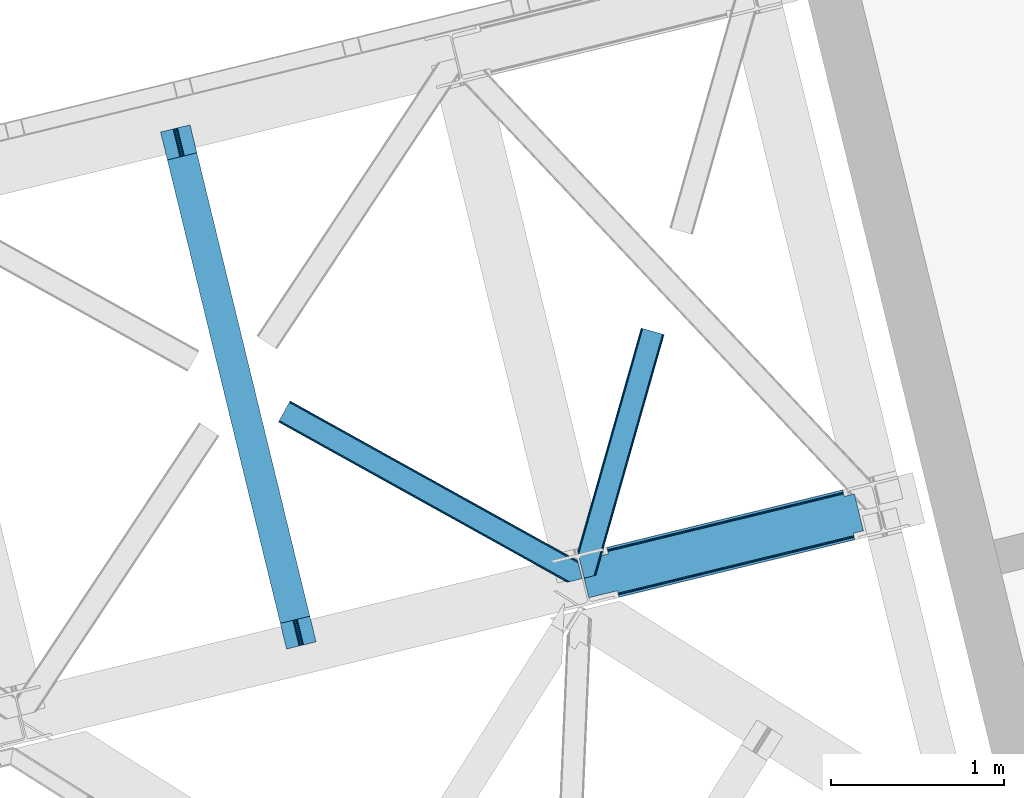
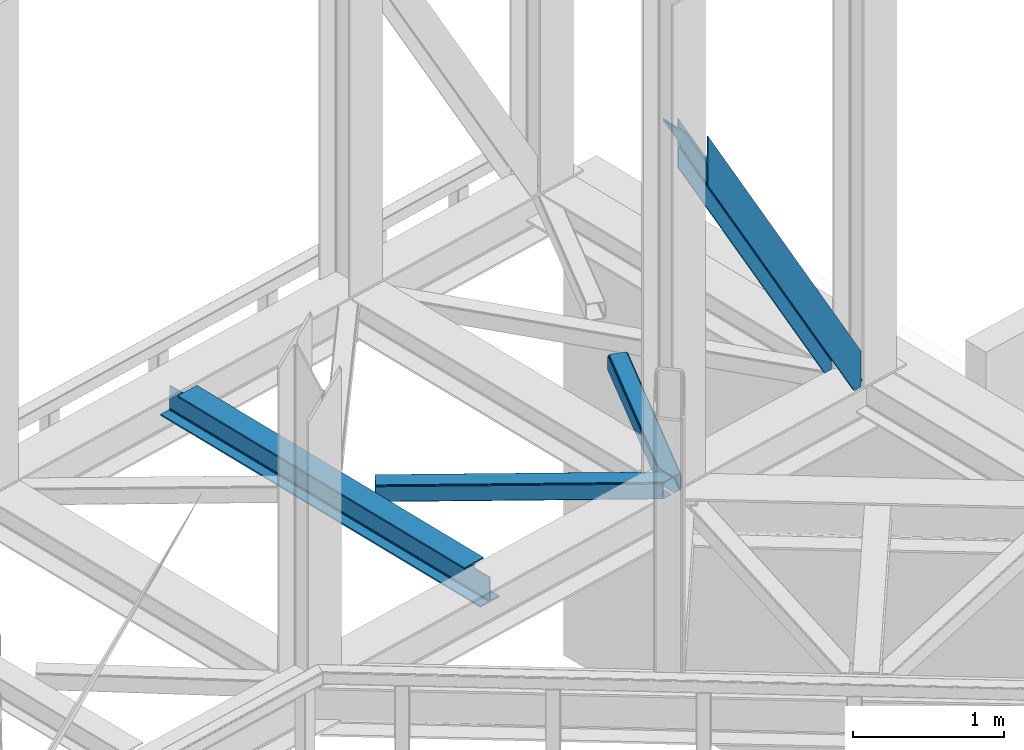
# One storey, part 82 of 93: 3 members, 1 beam.
"""IFC4 building model written with IfcOpenShell, lengths in millimetres."""

from ifc_helpers import new_model, entity, si_unit, converted_unit, derived_unit, direction, frame, origin, place, context, subcontext, project, spatial, triangles, polygons, material, type_object, element, save


model = new_model("IFC4")

# Units and contexts
model_context = context("Model", 3, precision=0.01, world=origin(), true_north=direction((6.12303176911189e-17, 1.0)))
plan_context = context("Plan", 3, precision=0.01, world=origin(), true_north=direction((6.12303176911189e-17, 1.0)))
body_context = subcontext(model_context, "Body", "Model", "MODEL_VIEW")
ifc_project = project(units=[si_unit("LENGTHUNIT", "METRE", prefix="MILLI"), si_unit("AREAUNIT", "SQUARE_METRE"), si_unit("VOLUMEUNIT", "CUBIC_METRE"), converted_unit("PLANEANGLEUNIT", "DEGREE", entity("IfcRatioMeasure", 0.0174532925199433), si_unit("PLANEANGLEUNIT", "RADIAN"), dimensions=[0, 0, 0, 0, 0, 0, 0]), si_unit("MASSUNIT", "GRAM", prefix="KILO"), derived_unit("MASSDENSITYUNIT", [(si_unit("MASSUNIT", "GRAM", prefix="KILO"), 1), (si_unit("LENGTHUNIT", "METRE"), -3)]), derived_unit("MOMENTOFINERTIAUNIT", [(si_unit("LENGTHUNIT", "METRE"), 4)]), si_unit("TIMEUNIT", "SECOND"), si_unit("FREQUENCYUNIT", "HERTZ"), si_unit("THERMODYNAMICTEMPERATUREUNIT", "DEGREE_CELSIUS"), derived_unit("THERMALTRANSMITTANCEUNIT", [(si_unit("MASSUNIT", "GRAM", prefix="KILO"), 1), (si_unit("THERMODYNAMICTEMPERATUREUNIT", "KELVIN"), -1), (si_unit("TIMEUNIT", "SECOND"), -3)]), derived_unit("VOLUMETRICFLOWRATEUNIT", [(si_unit("LENGTHUNIT", "METRE"), 3), (si_unit("TIMEUNIT", "SECOND"), -1)]), derived_unit("MASSFLOWRATEUNIT", [(si_unit("MASSUNIT", "GRAM", prefix="KILO"), 1), (si_unit("TIMEUNIT", "SECOND"), -1)]), derived_unit("ROTATIONALFREQUENCYUNIT", [(si_unit("TIMEUNIT", "SECOND"), -1)]), si_unit("ELECTRICCURRENTUNIT", "AMPERE"), si_unit("ELECTRICVOLTAGEUNIT", "VOLT"), si_unit("POWERUNIT", "WATT"), si_unit("FORCEUNIT", "NEWTON", prefix="KILO"), si_unit("ILLUMINANCEUNIT", "LUX"), si_unit("LUMINOUSFLUXUNIT", "LUMEN"), si_unit("LUMINOUSINTENSITYUNIT", "CANDELA"), derived_unit("USERDEFINED", [(si_unit("MASSUNIT", "GRAM", prefix="KILO"), -1), (si_unit("LENGTHUNIT", "METRE"), -2), (si_unit("TIMEUNIT", "SECOND"), 3), (si_unit("LUMINOUSFLUXUNIT", "LUMEN"), 1)]), derived_unit("LINEARVELOCITYUNIT", [(si_unit("LENGTHUNIT", "METRE"), 1), (si_unit("TIMEUNIT", "SECOND"), -1)]), si_unit("PRESSUREUNIT", "PASCAL"), derived_unit("USERDEFINED", [(si_unit("LENGTHUNIT", "METRE"), -2), (si_unit("MASSUNIT", "GRAM", prefix="KILO"), 1), (si_unit("TIMEUNIT", "SECOND"), -2)]), derived_unit("LINEARFORCEUNIT", [(si_unit("MASSUNIT", "GRAM", prefix="KILO"), 1), (si_unit("LENGTHUNIT", "METRE"), 1), (si_unit("TIMEUNIT", "SECOND"), -2), (si_unit("LENGTHUNIT", "METRE"), -1)]), derived_unit("PLANARFORCEUNIT", [(si_unit("MASSUNIT", "GRAM", prefix="KILO"), 1), (si_unit("LENGTHUNIT", "METRE"), 1), (si_unit("TIMEUNIT", "SECOND"), -2), (si_unit("LENGTHUNIT", "METRE"), -2)])], contexts=[model_context, plan_context])

# Site, building, storey
site_placement = place(None, origin())
site = spatial("IfcSite", under=ifc_project, at=site_placement, CompositionType="ELEMENT")
building_placement = place(site_placement, origin())
building = spatial("IfcBuilding", under=site, at=building_placement, CompositionType="ELEMENT")
storey_placement = place(building_placement, frame((0.0, 0.0, 15900.0)))
storey = spatial("IfcBuildingStorey", under=building, at=storey_placement, CompositionType="ELEMENT", Elevation=15900.0)

# Beam
ifc_material = material(Name="Metal painted (White)")
beam_type = type_object("IfcBeamType", PredefinedType="BEAM")
beam_placement = place(storey_placement, frame((-4605.04883182571, 16672.3998394373, 3441.0)))
element("IfcBeam", 1, at=beam_placement, inside=storey, type_object=beam_type, material=ifc_material, ObjectType="Steel Beam", PredefinedType="BEAM", context=body_context, shape_type="Tessellation", body=[
    polygons([(896.722476515621, 41.4445662733103, 11.000000000004), (896.72247651562, 41.4445662733103, 2.16573425859679e-12), (170.02161017477, 3022.65205668042, 2.16573425859679e-12), (170.02161017477, 3022.65205668042, 11.000000000004), (830.656936562001, 25.3403919499699, 11.000000000004), (103.95607022115, 3006.54788235708, 11.000000000004), (824.708186540703, 23.8903211957417, 12.2179274798217), (98.007320199853, 3005.09781160286, 12.2179274798217), (819.665079784591, 22.6610105689216, 15.6862915010257), (92.9642134437405, 3003.86850097604, 15.6862915010257), (816.295383581418, 21.839611468714, 20.8770650821657), (89.5945172405684, 3003.04710187583, 20.8770650821657), (815.112103631724, 21.5511744621227, 27.0000000000047), (88.4112372908739, 3002.75866486924, 27.0000000000047), (81.6103728838909, 3001.1008822183, 27.0000000000047), (81.6103728838915, 3001.10088221831, 203.000000000006), (88.4112372908706, 3002.75866486924, 203.000000000006), (5.41433564649196e-13, 2981.20749040711, 2.16573425859679e-12), (2.16573425859679e-12, 2981.20749040711, 10.9999999999997), (66.0655399536302, 2997.31166473046, 11.000000000004), (72.0142899749205, 2998.76173548468, 12.2179274798195), (77.0573967310308, 2999.99104611151, 15.6862915010192), (80.427092934211, 3000.81244521171, 20.8770650821657), (815.112103631721, 21.5511744621206, 203.000000000006), (808.311239224742, 19.8933918111897, 203.000000000006), (808.311239224741, 19.8933918111897, 27.0000000000047), (807.127959275061, 19.6049548046028, 20.8770650821657), (803.75826307188, 18.7835557043952, 15.6862915010192), (798.71515631577, 17.5542450775707, 12.2179274798195), (792.76640629448, 16.104174323349, 11.000000000004), (726.700866340852, 2.16573425859679e-12, 10.9999999999997), (726.700866340851, 2.16573425859679e-12, 2.16573425859679e-12), (779.142354126241, 169.113117828151, 203.069793472056), (127.487542634277, 2842.45257527589, 203.000000000006), (127.710423423425, 2841.53823284147, 203.617301946336), (127.723337667946, 2841.48525286857, 217.000003693143), (778.997150924595, 169.708652488344, 217.000003676718), (778.998021532492, 169.705081047464, 204.00000679514), (772.432053048639, 167.083518913905, 203.006342977999), (772.209205347559, 167.99787105405, 203.617301946336), (772.196291103036, 168.050851026943, 217.000003693143), (120.922477846387, 2839.82745140717, 217.000003676718), (120.921607238492, 2839.83102284805, 204.00000679514), (120.77730764944, 2840.42299574862, 203.076120467494), (120.686678227296, 2840.79479262496, 203.000000000006), (780.180635648643, 169.996249461788, 223.122939328039), (783.549632057316, 170.820519285667, 228.313710402595), (788.592267461342, 172.051763510973, 231.782072735464), (794.540846332051, 173.502536365655, 232.999999602236), (860.606297197569, 189.607076149589, 232.999999283132), (860.604823861134, 189.613120126462, 243.999994005812), (690.583442957211, 148.167613329572, 243.999994827032), (690.58491629365, 148.161569352698, 233.000000104353), (756.650367159178, 164.266109136635, 232.999999785253), (762.599272287504, 165.715543604856, 231.782072861016), (767.642836794641, 166.94297642799, 228.313710479427), (771.01322370438, 167.761542085424, 223.12293937232), (119.738993122354, 2839.53985443373, 223.122939328039), (116.369996713678, 2838.71558460985, 228.313710402595), (111.327361309646, 2837.48434038454, 231.782072735464), (105.378782438949, 2836.03356752986, 232.999999602236), (39.3133315734155, 2819.92902774593, 232.999999283128), (39.3148049098525, 2819.92298376905, 243.999994005812), (209.336185813776, 2861.36849056595, 243.999994827032), (209.334712477334, 2861.37453454282, 233.000000104357), (143.269261611822, 2845.26999475889, 232.999999785253), (137.320356483485, 2843.82056029066, 231.782072861012), (132.276791976353, 2842.59312746752, 228.313710479427), (128.906405066617, 2841.77456181009, 223.12293937232)], [[[1, 2, 3, 4]], [[5, 1, 4, 6]], [[7, 5, 6, 8]], [[9, 7, 8, 10]], [[11, 9, 10, 12]], [[13, 11, 12, 14]], [[15, 16, 17, 14, 12, 10, 8, 6, 4, 3, 18, 19, 20, 21, 22, 23]], [[13, 24, 25, 26, 27, 28, 29, 30, 31, 32, 2, 1, 5, 7, 9, 11]], [[2, 32, 18, 3]], [[32, 31, 19, 18]], [[31, 30, 20, 19]], [[27, 26, 15, 23]], [[28, 27, 23, 22]], [[29, 28, 22, 21]], [[30, 29, 21, 20]], [[33, 24, 13, 14, 17, 34, 35, 36, 37, 38]], [[25, 39, 40, 41, 42, 43, 44, 16, 15, 26]], [[39, 25, 24, 33]], [[45, 34, 17, 16]], [[41, 40, 38, 37, 46, 47, 48, 49, 50, 51, 52, 53, 54, 55, 56, 57]], [[42, 58, 59, 60, 61, 62, 63, 64, 65, 66, 67, 68, 69, 36, 35, 43]], [[46, 37, 36, 69]], [[47, 46, 69, 68]], [[48, 47, 68, 67]], [[49, 48, 67, 66]], [[50, 49, 66, 65]], [[51, 50, 65, 64]], [[52, 51, 64, 63]], [[53, 52, 63, 62]], [[54, 53, 62, 61]], [[55, 54, 61, 60]], [[56, 55, 60, 59]], [[57, 56, 59, 58]], [[41, 57, 58, 42]]], closed=False),
])

# Members
member_type_1 = type_object("IfcMemberType", PredefinedType="BRACE")
member_1_placement = place(storey_placement, frame((-2187.21835717022, 16968.3557591436, 3695.0)))
element("IfcMember", 2, at=member_1_placement, inside=storey, type_object=member_type_1, ObjectType="Steel Vertical Brace", PredefinedType="BRACE", context=body_context, shape_type="Tessellation", body=[
    polygons([(1523.65378747275, 333.032085942706, 0.0), (1582.15074591361, 347.2913384483, 0.0), (1585.22948512248, 334.661161692462, 0.0), (1526.73252668162, 320.401909186869, 0.0), (225.056603724429, 3.10463150599028, 2308.00987734577), (221.977864515554, 15.734808261831, 2308.00987734577), (221.977864515553, 15.734808261831, 2462.87833808595), (1582.1507459136, 347.291338448298, 51.1471308030944), (225.056603724427, 3.10463150599028, 2706.38533905685), (1585.22948512248, 334.661161692462, 294.654131773986), (217.71499484172, 33.2227453083746, 2515.66308676267), (216.294038283785, 39.0520576572275, 2515.66308676267), (216.294038283786, 39.0520576572275, 2498.73212963995), (217.714994841717, 33.2227453083768, 2498.73212963995), (219.34632444024, 26.5304015344206, 2496.00292226562), (220.72929889541, 20.8569064337962, 2488.23079722503), (221.653372883133, 17.065998205232, 2476.59899010114), (221.977864515552, 15.734808261831, 2706.38533905685), (221.977864515552, 15.734808261831, 2551.51687831667), (221.653372883138, 17.0659982052385, 2537.79622630148), (220.729298895404, 20.856906433807, 2526.16441917759), (219.346324440226, 26.5304015344141, 2518.39229413699), (1576.46691968183, 370.608587843693, 87.0009223570892), (1576.46691968183, 370.608587843693, 103.931879479809), (1577.88787623976, 364.779275494842, 103.9318794798), (1579.51920583827, 358.086931720883, 106.661086854137), (1580.90218029345, 352.413436620276, 114.433211894731), (1581.82625428118, 348.622528391703, 126.065019018618), (1582.15074591359, 347.291338448298, 139.785671033808), (1582.15074591359, 347.291338448298, 294.654131773986), (1581.82625428118, 348.622528391697, 64.8677828182753), (1580.90218029345, 352.413436620263, 76.4995899421711), (1579.51920583828, 358.086931720888, 84.2717149827655), (1577.88787623976, 364.779275494846, 87.0009223570848), (163.955471732923, 253.765062506492, 2498.73212963995), (162.534515174981, 259.594374855341, 2498.73212963995), (1522.70739657303, 591.15090504181, 87.0009223570935), (1524.12835313097, 585.321592692961, 87.0009223570935), (1524.73254220655, 584.95422971039, 86.1395897830593), (1525.33673128212, 584.586866727814, 85.2782572090295), (1573.43212950823, 596.310628884719, 0.0), (1625.29704387311, 383.540728151737, 0.0), (1577.201645647, 371.81696599483, 85.2782572090295), (1576.83428266443, 371.212776919264, 86.1395897830593), (215.689849208223, 39.4194206398013, 2499.59346221398), (215.085660132657, 39.7867836223773, 2500.45479478801), (51.8649143648901, 2.16573425859679e-12, 2789.86253966195), (6.76791955811495e-12, 212.769900732984, 2789.86253966195), (163.220745767773, 252.556684355359, 2500.45479478801), (163.588108750349, 253.160873430927, 2499.59346221398), (163.220745767771, 252.556684355359, 2517.38575191073), (5.41433564649196e-13, 212.769900732984, 2806.79349678468), (51.8649143648844, 0.0, 2806.79349678468), (215.085660132655, 39.7867836223773, 2517.38575191073), (215.68984920822, 39.4194206398013, 2516.5244193367), (1576.83428266442, 371.212776919264, 103.070546905779), (1577.201645647, 371.81696599483, 102.209214331749), (1634.84579817246, 385.868338036035, 0.0), (1582.98088380758, 598.638238769017, 0.0), (1525.33673128211, 584.586866727814, 102.209214331749), (1524.73254220655, 584.954229710388, 103.070546905779), (1524.12835313097, 585.321592692961, 103.931879479813), (1522.70739657303, 591.15090504181, 103.931879479809), (162.534515174979, 259.594374855341, 2515.66308676267), (163.955471732921, 253.765062506492, 2515.66308676267), (163.588108750346, 253.160873430927, 2516.5244193367), (160.903185576473, 266.286718629297, 2518.39229413699), (159.520211121304, 271.960213729915, 2526.16441917758), (158.596137133563, 275.751121958494, 2537.79622630147), (158.271645501151, 277.082311901891, 2551.51687831666), (158.271645501151, 277.082311901886, 2706.38533905685), (155.192906292277, 289.712488657727, 2706.38533905685), (155.192906292278, 289.712488657727, 2308.00987734577), (158.271645501152, 277.082311901886, 2308.00987734577), (158.271645501151, 277.082311901886, 2462.87833808595), (158.596137133566, 275.75112195849, 2476.59899010114), (159.520211121302, 271.960213729923, 2488.23079722503), (160.903185576474, 266.286718629303, 2496.00292226561), (1521.07606697452, 597.843248815768, 84.2717149827568), (1519.69309251934, 603.516743916388, 76.4995899421711), (1518.76901853161, 607.307652144959, 64.8677828182753), (1518.44452689919, 608.638842088356, 51.1471308030858), (1518.44452689919, 608.638842088356, 0.0), (1515.36578769032, 621.269018844194, 0.0), (1515.36578769032, 621.269018844194, 294.654131773986), (1518.44452689919, 608.638842088356, 294.654131773986), (1518.44452689919, 608.638842088358, 139.785671033799), (1518.76901853161, 607.307652144961, 126.065019018618), (1519.69309251935, 603.516743916384, 114.433211894731), (1521.07606697452, 597.843248815764, 106.661086854141), (1459.94756845834, 594.379589582763, 0.0), (1456.86882924947, 607.009766338602, 0.0)], [[[1, 2, 3, 4]], [[5, 6, 1, 4]], [[6, 7, 8, 2, 1]], [[9, 5, 4, 3, 10]], [[11, 12, 13, 14, 15, 16, 17, 7, 6, 5, 9, 18, 19, 20, 21, 22]], [[23, 24, 25, 26, 27, 28, 29, 30, 10, 3, 2, 8, 31, 32, 33, 34]], [[34, 33, 15, 14]], [[33, 32, 16, 15]], [[32, 31, 17, 16]], [[31, 8, 7, 17]], [[18, 9, 10, 30]], [[19, 18, 30, 29]], [[29, 28, 20, 19]], [[28, 27, 21, 20]], [[27, 26, 22, 21]], [[26, 25, 11, 22]], [[35, 36, 37, 38, 39, 40, 41, 42, 43, 44, 23, 34, 14, 13, 45, 46, 47, 48, 49, 50]], [[51, 52, 53, 54, 55, 12, 11, 25, 24, 56, 57, 58, 59, 60, 61, 62, 63, 64, 65, 66]], [[54, 53, 47, 46]], [[48, 47, 53, 52]], [[52, 51, 49, 48]], [[57, 43, 42, 58]], [[59, 58, 42, 41]], [[59, 41, 40, 60]], [[65, 64, 67, 68, 69, 70, 71, 72, 73, 74, 75, 76, 77, 78, 36, 35]], [[62, 38, 37, 79, 80, 81, 82, 83, 84, 85, 86, 87, 88, 89, 90, 63]], [[82, 81, 76, 75]], [[81, 80, 77, 76]], [[80, 79, 78, 77]], [[79, 37, 36, 78]], [[75, 74, 91, 83, 82]], [[92, 84, 83, 91]], [[74, 73, 92, 91]], [[73, 72, 85, 84, 92]], [[63, 90, 67, 64]], [[90, 89, 68, 67]], [[89, 88, 69, 68]], [[88, 87, 70, 69]], [[71, 70, 87, 86]], [[72, 71, 86, 85]]], closed=False),
])
member_type_2 = type_object("IfcMemberType", PredefinedType="BRACE")
member_2_placement = place(storey_placement, frame((-3925.98274612427, 17057.1809417725, 3510.01988525391)))
element("IfcMember", 3, at=member_2_placement, inside=storey, type_object=member_type_2, ObjectType="Steel Horizontal Brace", PredefinedType="BRACE", context=body_context, shape_type="Tessellation", body=[
    triangles([(1726.38590240479, 124.059869384764, 129.196765136719), (1725.95627746582, 125.821389770506, 122.499499511719), (67.3144958496091, 1045.27805786133, 129.196765136719), (67.9638748168945, 1046.44310302734, 122.499499511719), (1727.60908355713, 119.041571044923, 134.87548828125), (65.475363922119, 1041.96198120117, 134.87548828125), (1729.43993110657, 111.53040161133, 138.668280029298), (62.7171020507813, 1036.99833068848, 138.668280029298), (1731.59939231873, 102.671640014647, 140.000756835936), (59.4673004150391, 1031.14403686523, 140.000756835936), (1725.95627746582, 125.821389770506, 17.5000946044929), (67.9638748168945, 1046.44310302734, 17.5000946044929), (1689.2107006073, 6.10660400390771, 140.000756835936), (8.49657440185547, 939.3461517334, 140.000756835936), (1751.44047775269, 21.2754455566392, 140.000756835936), (1679.62218704224, 3.76953735351708, 138.668280029298), (5.24677276611328, 933.491857910158, 138.668280029298), (1671.49782829285, 1.78942565917896, 134.87548828125), (2.48822021484375, 928.527044677736, 134.87548828125), (1666.06647377014, 0.465087890625, 129.196765136719), (0.644728088378542, 925.209805297851, 129.196765136719), (1664.15975875854, 0.0, 122.499499511719), (0.0, 924.045922851561, 122.499499511719), (1664.15975875854, 0.0, 17.5000946044929), (0.0, 924.045922851561, 17.5000946044929), (2.48822021484375, 928.527044677736, 5.12643127441333), (5.24677276611328, 933.491857910158, 1.33247680664135), (1584.29559288025, 56.7035156249985, 1.33247680664135), (1585.91380805969, 50.0643859863267, 4.50088806152417), (0.644728088378542, 925.209805297851, 10.8039916992202), (1586.87683067322, 48.7842315673843, 5.13573303222802), (1587.06024971008, 48.5423858642571, 5.2554931640625), (1587.43377342224, 48.0505554199226, 5.50082702636792), (1670.97823791504, 1.66268920898438, 5.50082702636792), (1666.06647377014, 0.465087890625, 10.8039916992202), (1586.28282623291, 49.5713928222649, 4.74505920410229), (1586.67146530151, 49.0574707031265, 5.00085754394604), (1582.13598632813, 65.5622772216811, 0.0), (8.49657440185547, 939.3461517334, 0.0), (1548.27744255066, 204.463101196288, 0.0), (59.4673004150391, 1031.14403686523, 0.0), (1544.52592735291, 220.383059692384, 4.86481933593677), (1544.64423408508, 220.684204101563, 5.1694519042976), (1545.00700263977, 220.667926025391, 5.33688354492188), (1545.36032409668, 220.652810668944, 5.50082702636792), (1544.54758300781, 220.687692260741, 5.12643127441333), (1544.49962081909, 219.960992431639, 4.50088806152417), (1546.11783599854, 213.323025512695, 1.33247680664135), (1726.19158287048, 124.856332397459, 12.5003997802742), (1724.64502029419, 124.700527954101, 10.9621215820298), (67.3144958496091, 1045.27805786133, 10.8039916992202), (65.475363922119, 1041.96198120117, 5.12643127441333), (1719.1595993042, 124.149398803711, 5.50082702636792), (62.7171020507813, 1036.99833068848, 1.33247680664135), (1744.64002075195, 19.6185699462876, 5.50082702636792), (1729.74921455383, 110.261874389649, 12.5003997802742), (1726.73631706238, 105.026147460936, 8.3320495605476), (1746.09501914978, 19.9731994628892, 7.00073547363354), (1727.30750312805, 97.0464019775391, 7.00073547363354), (62.0749900817868, 1035.84142456055, 12.1260040283196), (59.3210884094237, 1030.87893676758, 8.3320495605476), (1728.64317741394, 114.798806762694, 17.8035644531265), (1728.21355247498, 116.561489868163, 24.5008300781265), (63.9184822082516, 1039.15866394043, 17.8035644531265), (64.5635009765624, 1040.32370910644, 24.5008300781265), (56.0712867736816, 1025.02464294434, 7.00073547363354), (1699.23290863037, 8.54947814941261, 7.00073547363354), (11.8922973632812, 945.465545654297, 7.00073547363354), (1728.21355247498, 116.561489868163, 115.499926757813), (64.5635009765624, 1040.32370910644, 115.499926757813), (1729.86635856628, 109.780508422853, 127.875915527344), (1728.64317741394, 114.798806762694, 122.197192382813), (1733.85666732788, 93.411740112304, 133.00118408203), (1731.69720611572, 102.270501708983, 131.668707275392), (1751.44047775269, 21.2754455566392, 133.00118408203), (56.0712867736816, 1025.02464294434, 133.00118408203), (59.3210884094237, 1030.87893676758, 131.668707275392), (62.0749900817868, 1035.84142456055, 127.875915527344), (63.9184822082516, 1039.15866394043, 122.197192382813), (1699.23290863037, 8.54947814941261, 133.00118408203), (11.8922973632812, 945.465545654297, 133.00118408203), (5.88859405517542, 934.64760131836, 12.1260040283196), (8.64249572753897, 939.611251831055, 8.3320495605476), (3.40037384033167, 930.166479492189, 24.5008300781265), (4.04510192871066, 931.330361938475, 17.8035644531265), (5.88859405517542, 934.64760131836, 127.875915527344), (8.64249572753897, 939.611251831055, 131.668707275392), (3.40037384033167, 930.166479492189, 115.499926757813), (4.04510192871066, 931.330361938475, 122.197192382813), (1681.51553077698, 4.23113708496021, 127.875915527344), (1689.64439506531, 6.21241149902198, 131.668707275392), (1676.08868179321, 2.90796203613354, 122.197192382813), (1674.18182144165, 2.44287414550854, 115.499926757813), (1674.18182144165, 2.44287414550854, 24.5008300781265), (1681.51553077698, 4.23113708496021, 12.1260040283196), (1676.08868179321, 2.90796203613354, 17.8035644531265), (1689.64439506531, 6.21241149902198, 8.3320495605476)], [[1, 2, 3], [4, 3, 2], [5, 1, 6], [3, 6, 1], [7, 5, 8], [6, 8, 5], [9, 7, 10], [8, 10, 7], [2, 11, 12], [12, 4, 2], [13, 9, 14], [13, 15, 9], [10, 14, 9], [16, 13, 14], [14, 17, 16], [18, 16, 17], [17, 19, 18], [20, 18, 19], [19, 21, 20], [22, 20, 21], [21, 23, 22], [24, 22, 23], [23, 25, 24], [26, 27, 28], [28, 29, 26], [30, 26, 31], [31, 32, 30], [32, 33, 30], [34, 35, 33], [30, 33, 35], [36, 37, 26], [37, 31, 26], [26, 29, 36], [38, 28, 27], [27, 39, 38], [35, 24, 30], [25, 30, 24], [40, 38, 39], [39, 41, 40], [42, 36, 29], [43, 36, 42], [43, 37, 36], [44, 32, 31], [31, 43, 44], [31, 37, 43], [45, 33, 32], [32, 44, 45], [42, 46, 43], [29, 47, 42], [40, 47, 38], [40, 48, 47], [29, 38, 47], [29, 28, 38], [12, 49, 50], [12, 11, 49], [51, 50, 45], [45, 52, 51], [45, 43, 52], [50, 53, 45], [54, 52, 45], [48, 40, 41], [41, 54, 48], [47, 48, 54], [50, 51, 12], [33, 53, 34], [33, 45, 53], [53, 55, 34], [56, 53, 50], [57, 53, 56], [50, 49, 56], [58, 55, 59], [59, 53, 57], [53, 59, 55], [60, 61, 57], [60, 56, 62], [62, 63, 64], [65, 64, 63], [62, 64, 60], [57, 56, 60], [59, 57, 66], [61, 66, 57], [67, 59, 68], [67, 58, 59], [66, 68, 59], [63, 69, 65], [70, 65, 69], [71, 5, 7], [5, 71, 72], [73, 74, 9], [74, 71, 7], [75, 73, 15], [9, 15, 73], [74, 7, 9], [49, 62, 56], [11, 2, 63], [63, 62, 11], [49, 11, 62], [2, 69, 63], [72, 1, 5], [2, 1, 72], [69, 2, 72], [74, 73, 76], [76, 77, 74], [71, 74, 77], [77, 78, 71], [72, 71, 78], [78, 79, 72], [69, 72, 79], [79, 70, 69], [73, 80, 81], [80, 73, 75], [81, 76, 73], [51, 60, 64], [65, 4, 12], [51, 64, 12], [51, 52, 60], [64, 65, 12], [60, 52, 54], [66, 41, 39], [41, 61, 54], [61, 41, 66], [61, 60, 54], [3, 78, 6], [70, 4, 65], [4, 79, 3], [79, 4, 70], [3, 79, 78], [10, 76, 14], [8, 6, 78], [78, 77, 8], [77, 76, 10], [10, 8, 77], [82, 27, 26], [39, 68, 66], [39, 83, 68], [83, 39, 27], [82, 83, 27], [84, 25, 23], [30, 85, 82], [26, 30, 82], [85, 30, 25], [84, 85, 25], [17, 86, 19], [14, 76, 81], [81, 87, 14], [87, 86, 17], [17, 14, 87], [21, 19, 86], [23, 88, 84], [89, 23, 21], [23, 89, 88], [89, 21, 86], [90, 91, 16], [18, 90, 16], [92, 18, 20], [92, 22, 93], [18, 92, 90], [22, 92, 20], [91, 13, 16], [15, 80, 75], [15, 13, 80], [91, 80, 13], [22, 94, 93], [34, 95, 96], [96, 94, 24], [24, 94, 22], [96, 35, 34], [35, 96, 24], [55, 67, 34], [67, 97, 34], [97, 95, 34], [55, 58, 67], [97, 67, 68], [68, 83, 97], [95, 97, 83], [83, 82, 95], [96, 95, 82], [82, 85, 96], [94, 96, 85], [85, 84, 94], [93, 94, 88], [84, 88, 94], [92, 93, 89], [88, 89, 93], [90, 92, 86], [89, 86, 92], [91, 90, 87], [86, 87, 90], [80, 91, 81], [87, 81, 91]]),
])
member_type_3 = type_object("IfcMemberType", PredefinedType="BRACE")
member_3_placement = place(storey_placement, frame((-2200.60041618347, 17081.2992370605, 3510.01988525391)))
element("IfcMember", 4, at=member_3_placement, inside=storey, type_object=member_type_3, ObjectType="Steel Horizontal Brace", PredefinedType="BRACE", context=body_context, shape_type="Tessellation", body=[
    triangles([(382.458631896973, 1437.45993347168, 140.000756835936), (376.014548492432, 1439.28889160157, 138.668280029298), (5.18718338012695, 133.445343017578, 138.668280029298), (8.40283012390137, 120.253125000003, 140.000756835936), (370.552672576904, 1440.83879699707, 134.87548828125), (2.46118698120108, 144.628381347658, 134.87548828125), (366.905947494507, 1441.87594299317, 129.196765136719), (0.639641189575286, 152.101181030273, 129.196765136719), (365.625211715698, 1442.23987426758, 122.499499511719), (0.0, 154.725439453126, 122.499499511719), (365.625211715698, 1442.23987426758, 17.5000946044929), (0.0, 154.725439453126, 17.5000946044929), (86.8012424468993, 11.9643859863281, 140.000756835936), (483.46365852356, 1408.77563781738, 140.000756835936), (37.7160118103025, 0.0, 140.000756835936), (500.297078704834, 1403.99453430176, 122.499499511719), (499.016342926025, 1404.35846557617, 129.196765136719), (106.348595809936, 16.7292114257834, 122.499499511719), (104.86191329956, 16.3664428710945, 129.196765136719), (495.369617843628, 1405.39561157227, 134.87548828125), (100.623509216308, 15.3339477539084, 134.87548828125), (489.9077419281, 1406.9466796875, 138.668280029298), (94.2839252471922, 13.7886932373076, 138.668280029298), (500.297078704834, 1403.99453430176, 17.5000946044929), (106.348595809936, 16.7292114257834, 17.5000946044929), (370.552672576904, 1440.83879699707, 5.12643127441333), (376.014548492432, 1439.28889160157, 1.33247680664135), (64.4095859527588, 341.997729492188, 1.33247680664135), (366.905947494507, 1441.87594299317, 10.8039916992202), (57.6633407592772, 340.35364379883, 5.50082702636792), (1.58013610839816, 155.411444091798, 10.8039916992202), (0.350269317626953, 153.288317871094, 12.5003997802742), (6.16328659057626, 158.997271728516, 5.50082702636792), (382.458631896973, 1437.45993347168, 0.0), (71.8924140930176, 343.822036743164, 0.0), (101.030170440674, 15.4327789306662, 5.50082702636792), (149.676183700562, 186.73860168457, 5.50082702636792), (44.5164688110349, 1.65687561035156, 5.50082702636792), (109.170516586304, 352.90869140625, 5.50082702636792), (149.709902572632, 188.722201538087, 5.00085754394604), (489.9077419281, 1406.9466796875, 1.33247680664135), (495.369617843628, 1405.39561157227, 5.12643127441333), (149.739115905762, 190.703475952148, 4.50088806152417), (149.724436569214, 189.72214050293, 4.74854736328052), (147.329379272461, 200.588919067384, 1.33247680664135), (499.016342926025, 1404.35846557617, 10.8039916992202), (104.86191329956, 16.3664428710945, 10.8039916992202), (149.690717697144, 187.719937133792, 5.25316772460792), (483.46365852356, 1408.77563781738, 0.0), (144.113877868652, 213.779974365236, 0.0), (110.142114257812, 353.145886230472, 0.0), (109.541133499145, 352.999383544924, 5.42408752441406), (110.142114257812, 353.145886230472, 4.50088806152417), (43.0614704132081, 1.30224609375, 7.00073547363354), (14.8120319366453, 117.192846679689, 7.00073547363354), (10.8560234069823, 127.785223388673, 8.3320495605476), (5.64776573181143, 131.555923461914, 12.5003997802742), (377.289616012573, 1438.92844848633, 12.1260040283196), (373.638385391235, 1439.96326904297, 17.8035644531265), (4.00077323913547, 138.312487792969, 17.8035644531265), (389.191069793701, 1435.54725952149, 7.00073547363354), (382.751637268066, 1437.37738037109, 8.3320495605476), (372.357649612427, 1440.32720031738, 24.5008300781265), (3.36113204956064, 140.936746215823, 24.5008300781265), (78.9841323852538, 10.0586883544929, 7.00073547363354), (476.731220626831, 1410.68831176758, 7.00073547363354), (372.357649612427, 1440.32720031738, 115.499926757813), (3.36113204956064, 140.936746215823, 115.499926757813), (5.82231903076172, 130.839688110354, 127.875915527344), (4.00077323913547, 138.312487792969, 122.197192382813), (8.54831542968759, 119.656649780274, 131.668707275392), (11.763962173462, 106.464431762695, 133.00118408203), (37.7160118103025, 0.0, 133.00118408203), (373.638385391235, 1439.96326904297, 122.197192382813), (377.289616012573, 1438.92844848633, 127.875915527344), (382.751637268066, 1437.37738037109, 131.668707275392), (389.191069793701, 1435.54725952149, 133.00118408203), (78.9841323852538, 10.0586883544929, 133.00118408203), (476.731220626831, 1410.68831176758, 133.00118408203), (488.632529067993, 1407.30712280274, 12.1260040283196), (492.283905029297, 1406.27113952637, 17.8035644531265), (493.564640808105, 1405.90720825196, 24.5008300781265), (483.175158691406, 1408.8593536377, 8.3320495605476), (488.632529067993, 1407.30712280274, 127.875915527344), (493.564640808105, 1405.90720825196, 115.499926757813), (492.283905029297, 1406.27113952637, 122.197192382813), (483.175158691406, 1408.8593536377, 131.668707275392), (86.4623096466062, 11.8818328857451, 131.668707275392), (92.8063991546628, 13.4282501220732, 127.875915527344), (97.0402976989744, 14.4607452392593, 122.197192382813), (98.5314857482908, 14.8235137939482, 115.499926757813), (86.4623096466062, 11.8818328857451, 8.3320495605476), (97.0402976989744, 14.4607452392593, 17.8035644531265), (92.8063991546628, 13.4282501220732, 12.1260040283196), (98.5314857482908, 14.8235137939482, 24.5008300781265)], [[1, 2, 3], [3, 4, 1], [2, 5, 6], [6, 3, 2], [5, 7, 8], [8, 6, 5], [7, 9, 10], [10, 8, 7], [9, 11, 12], [12, 10, 9], [4, 13, 14], [13, 4, 15], [14, 1, 4], [16, 17, 18], [19, 18, 17], [17, 20, 19], [21, 19, 20], [20, 22, 21], [23, 21, 22], [22, 14, 23], [13, 23, 14], [24, 16, 25], [18, 25, 16], [26, 27, 28], [29, 26, 30], [11, 29, 31], [31, 12, 11], [31, 32, 12], [29, 30, 31], [33, 31, 30], [28, 30, 26], [27, 34, 35], [35, 28, 27], [36, 33, 37], [36, 38, 33], [30, 37, 33], [39, 37, 30], [40, 41, 42], [43, 41, 44], [40, 44, 41], [43, 45, 41], [46, 47, 37], [37, 42, 46], [37, 48, 42], [47, 36, 37], [46, 24, 25], [25, 47, 46], [49, 41, 50], [45, 50, 41], [51, 35, 34], [50, 51, 49], [34, 49, 51], [35, 30, 28], [35, 51, 52], [35, 52, 30], [52, 51, 53], [48, 37, 39], [44, 40, 53], [43, 44, 53], [53, 50, 43], [50, 53, 51], [45, 43, 50], [38, 54, 55], [33, 55, 56], [55, 33, 38], [57, 31, 33], [33, 56, 57], [32, 31, 57], [58, 59, 60], [60, 57, 58], [61, 62, 56], [56, 55, 61], [62, 58, 57], [57, 56, 62], [59, 63, 64], [64, 60, 59], [55, 65, 66], [65, 55, 54], [66, 61, 55], [63, 67, 68], [68, 64, 63], [69, 6, 70], [71, 72, 4], [72, 15, 4], [72, 73, 15], [3, 71, 4], [69, 3, 6], [69, 71, 3], [10, 64, 68], [8, 70, 6], [68, 70, 10], [70, 8, 10], [12, 64, 10], [32, 57, 60], [60, 64, 12], [12, 32, 60], [67, 74, 68], [70, 68, 74], [74, 75, 70], [69, 70, 75], [75, 76, 69], [71, 69, 76], [76, 77, 71], [72, 71, 77], [78, 72, 79], [78, 73, 72], [77, 79, 72], [46, 80, 81], [82, 16, 24], [46, 81, 24], [46, 42, 80], [81, 82, 24], [80, 42, 41], [66, 49, 34], [49, 83, 41], [83, 49, 66], [83, 80, 41], [17, 84, 20], [85, 16, 82], [16, 86, 17], [86, 16, 85], [17, 86, 84], [14, 79, 1], [22, 20, 84], [84, 87, 22], [87, 79, 14], [14, 22, 87], [58, 27, 26], [34, 61, 66], [34, 62, 61], [62, 34, 27], [58, 62, 27], [63, 11, 9], [29, 59, 58], [26, 29, 58], [59, 29, 11], [63, 59, 11], [2, 75, 5], [1, 79, 77], [77, 76, 1], [76, 75, 2], [2, 1, 76], [7, 5, 75], [9, 67, 63], [74, 9, 7], [9, 74, 67], [74, 7, 75], [23, 13, 88], [15, 78, 13], [78, 15, 73], [78, 88, 13], [89, 23, 88], [89, 21, 23], [19, 89, 90], [89, 19, 21], [18, 90, 91], [90, 18, 19], [65, 36, 92], [93, 94, 47], [94, 92, 36], [65, 38, 36], [38, 65, 54], [95, 93, 25], [47, 25, 93], [18, 95, 25], [95, 18, 91], [94, 36, 47], [82, 81, 95], [93, 95, 81], [81, 80, 93], [94, 93, 80], [80, 83, 94], [92, 94, 83], [83, 66, 92], [65, 92, 66], [85, 82, 95], [95, 91, 85], [79, 87, 88], [88, 78, 79], [87, 84, 89], [89, 88, 87], [84, 86, 90], [90, 89, 84], [86, 85, 91], [91, 90, 86]]),
])

save(model, "model.ifc")
